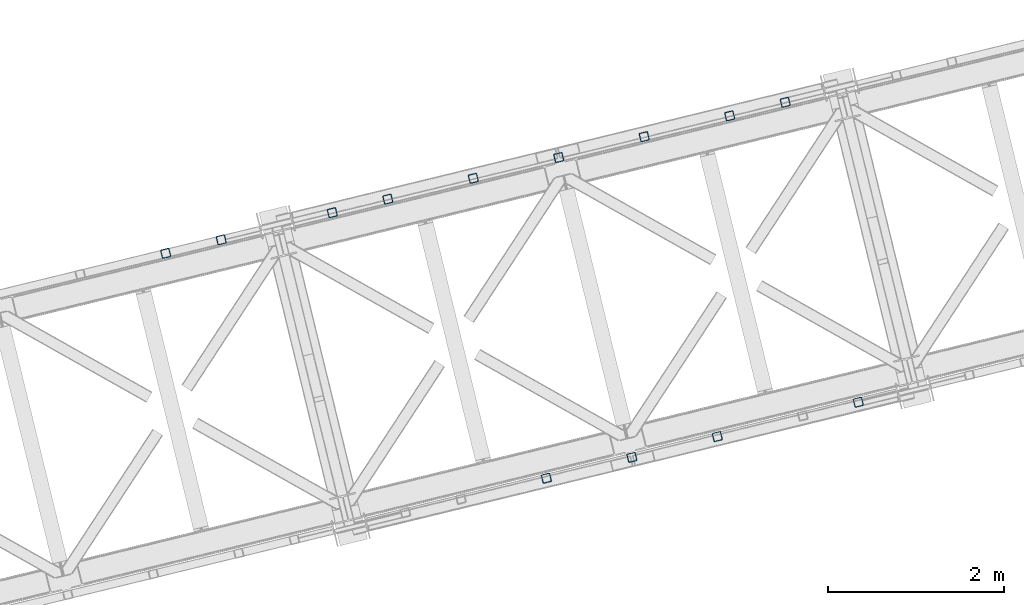
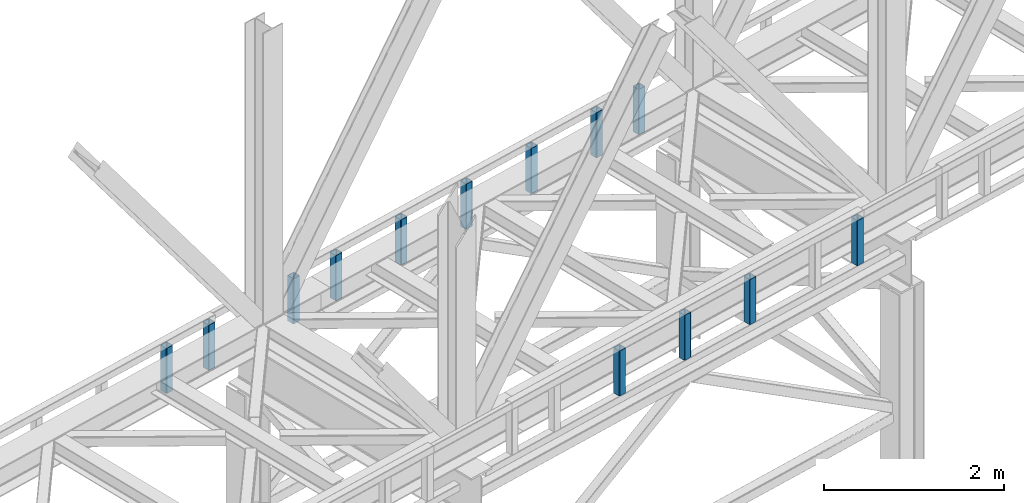
# One storey, part 7 of 92: 13 columns.
"""IFC4 building model written with IfcOpenShell, lengths in millimetres."""

import ifcopenshell
import ifcopenshell.guid

model = None  # the IFC model being written
_history = None  # IfcOwnerHistory: only IFC2X3 demands one
_inside = {}  # id of a spatial element -> (the spatial element, [elements in it])
_under = {}  # id of a project, library or spatial element -> (it, [spatial elements below it])
_declared = {}  # id of a project -> (the project, [libraries it declares])
_typed = {}  # id of a type object -> (the type object, [elements of that type])
_made_of = {}  # id of a material, layer set ... -> (it, [elements and type objects made of it])


def new_model(schema):
    """Start an empty IFC model of exactly this schema.

    Asked for "IFC4X3", IfcOpenShell would pick the latest addendum, in which some entities
    have other attributes; the version numbers below select the first issue.
    IFC2X3 requires an IfcOwnerHistory on every rooted entity: one is made here for all.
    """
    global model, _history
    if schema == "IFC4X3":
        model = ifcopenshell.file(schema_version=(4, 3, 0, 0))
    else:
        model = ifcopenshell.file(schema=schema)
    _inside.clear()
    _under.clear()
    _declared.clear()
    _typed.clear()
    _made_of.clear()
    _history = None
    if model.schema == "IFC2X3":
        org = make("IfcOrganization", Name="unknown")
        user = make(
            "IfcPersonAndOrganization",
            ThePerson=make("IfcPerson", FamilyName="unknown"),
            TheOrganization=org,
        )
        app = make(
            "IfcApplication",
            ApplicationDeveloper=org,
            Version="unknown",
            ApplicationFullName="unknown",
            ApplicationIdentifier="unknown",
        )
        _history = make(
            "IfcOwnerHistory",
            OwningUser=user,
            OwningApplication=app,
            ChangeAction="ADDED",
            CreationDate=0,
        )
    return model


def make(cls, **values):
    """One entity of the class cls with the attributes given. An attribute that is None is left unset."""
    return model.create_entity(
        cls, **{name: value for name, value in values.items() if value is not None}
    )


def entity(cls, *values):
    """Any entity or typed value of the class cls, its attributes in the order of the schema. None: left unset."""
    e = model.create_entity(cls)
    for i, value in enumerate(values):
        if value is not None:
            e[i] = value
    return e


def rooted(cls, **values):
    """An entity with a GlobalId (a new one), such as an element, a storey or a relation."""
    return make(cls, GlobalId=ifcopenshell.guid.new(), OwnerHistory=_history, **values)


def si_unit(unit_type, name, prefix=None):
    """IfcSIUnit, for example si_unit("LENGTHUNIT", "METRE", prefix="MILLI")."""
    return make("IfcSIUnit", UnitType=unit_type, Prefix=prefix, Name=name)


def converted_unit(unit_type, name, factor, base, dimensions=None, offset=None):
    """IfcConversionBasedUnit, such as the inch: factor (a typed value) times the base unit."""
    return make(
        "IfcConversionBasedUnit"
        if offset is None
        else "IfcConversionBasedUnitWithOffset",
        ConversionOffset=offset,
        Dimensions=None
        if dimensions is None
        else entity("IfcDimensionalExponents", *dimensions),
        UnitType=unit_type,
        Name=name,
        ConversionFactor=make(
            "IfcMeasureWithUnit", ValueComponent=factor, UnitComponent=base
        ),
    )


def derived_unit(unit_type, elements):
    """IfcDerivedUnit: a product of units, each with its exponent."""
    return make(
        "IfcDerivedUnit",
        Elements=[
            make("IfcDerivedUnitElement", Unit=unit, Exponent=power)
            for unit, power in elements
        ],
        UnitType=unit_type,
    )


def assignment(units):
    """IfcUnitAssignment: the units of a project."""
    return None if units is None else make("IfcUnitAssignment", Units=units)


def point(xyz):
    """IfcCartesianPoint."""
    return None if xyz is None else make("IfcCartesianPoint", Coordinates=xyz)


def direction(xyz):
    """IfcDirection."""
    return None if xyz is None else make("IfcDirection", DirectionRatios=xyz)


def frame(location, z_axis=None, x_axis=None):
    """IfcAxis2Placement3D, a coordinate frame: its origin and axes. An axis left out is left unset."""
    return make(
        "IfcAxis2Placement3D",
        Location=point(location),
        Axis=direction(z_axis),
        RefDirection=direction(x_axis),
    )


def origin():
    """The frame at (0, 0, 0) with its axes left unset."""
    return frame((0.0, 0.0, 0.0))


def place(relative_to, where):
    """IfcLocalPlacement: puts the frame where relative to a parent placement (None: the world)."""
    return make(
        "IfcLocalPlacement", PlacementRelTo=relative_to, RelativePlacement=where
    )


def context(
    kind, dimensions, precision=None, world=None, true_north=None, identifier=None
):
    """IfcGeometricRepresentationContext, for example the 3D "Model" context."""
    return make(
        "IfcGeometricRepresentationContext",
        ContextIdentifier=identifier,
        ContextType=kind,
        CoordinateSpaceDimension=dimensions,
        Precision=precision,
        WorldCoordinateSystem=world,
        TrueNorth=true_north,
    )


def subcontext(parent, identifier, kind, view, scale=None):
    """IfcGeometricRepresentationSubContext, for example "Body" below "Model"."""
    return make(
        "IfcGeometricRepresentationSubContext",
        ContextIdentifier=identifier,
        ContextType=kind,
        ParentContext=parent,
        TargetScale=scale,
        TargetView=view,
    )


def project(units=None, contexts=None):
    """IfcProject with its units and contexts."""
    return rooted(
        "IfcProject",
        Name="project",
        RepresentationContexts=contexts,
        UnitsInContext=assignment(units),
    )


def spatial(cls, under=None, at=None, **own):
    """A site, building, storey or space (cls), placed at a placement, below another one or the project."""
    s = rooted(cls, ObjectPlacement=at, **own)
    if under is not None:
        _under.setdefault(under.id(), (under, []))[1].append(s)
    return s


def point_list(points):
    """IfcCartesianPointList2D or 3D."""
    cls = (
        "IfcCartesianPointList2D" if len(points[0]) == 2 else "IfcCartesianPointList3D"
    )
    return make(cls, CoordList=points)


def indexed_curve(points, segments=None, self_intersect=None):
    """IfcIndexedPolyCurve: lines and arcs through numbered points (the first is 1)."""
    return make(
        "IfcIndexedPolyCurve",
        Points=point_list(points),
        Segments=segments,
        SelfIntersect=self_intersect,
    )


def outline(outer, holes=None, kind="AREA"):
    """IfcArbitraryClosedProfileDef: a profile drawn as a closed curve; with holes, ...WithVoids."""
    if holes is None:
        return make("IfcArbitraryClosedProfileDef", ProfileType=kind, OuterCurve=outer)
    return make(
        "IfcArbitraryProfileDefWithVoids",
        ProfileType=kind,
        OuterCurve=outer,
        InnerCurves=holes,
    )


def extrude(swept, where, along, depth):
    """IfcExtrudedAreaSolid: the profile swept, set in the frame where, extruded along a direction by depth."""
    return make(
        "IfcExtrudedAreaSolid",
        SweptArea=swept,
        Position=where,
        ExtrudedDirection=direction(along),
        Depth=depth,
    )


def shape(context_of_items, identifier, shape_type, items):
    """IfcShapeRepresentation: the items that make up one representation, for example the "Body"."""
    return make(
        "IfcShapeRepresentation",
        ContextOfItems=context_of_items,
        RepresentationIdentifier=identifier,
        RepresentationType=shape_type,
        Items=items,
    )


def made_of(thing, what):
    """Note that an element or type object is made of a material, layer set ...; save() writes the relation."""
    if what is not None:
        _made_of.setdefault(what.id(), (what, []))[1].append(thing)
    return thing


def type_object(cls, material=None, **own):
    """A type object (cls), such as IfcWallType, which elements share."""
    return made_of(rooted(cls, **own), material)


def element(
    cls,
    number,
    at=None,
    inside=None,
    cuts=None,
    type_object=None,
    material=None,
    context=None,
    identifier="Body",
    shape_type=None,
    held_by="IfcProductDefinitionShape",
    body=None,
    shapes=None,
    **own,
):
    """One element of the class cls, such as IfcWall. Its Tag is "e" and its number.

    at: its placement. inside: the storey or other place that contains it. cuts: it is an
    opening in that element (IfcRelVoidsElement). A single representation is given by context,
    identifier, shape_type and body (its items); several are given by shapes. held_by: the class
    of the entity that holds the representations. save() writes the other relations.
    """
    e = rooted(cls, Tag="e%d" % number, ObjectPlacement=at, **own)
    if body is not None:
        shapes = [shape(context, identifier, shape_type, body)]
    if shapes is not None:
        e.Representation = make(held_by, Representations=shapes)
    if inside is not None:
        _inside.setdefault(inside.id(), (inside, []))[1].append(e)
    if cuts is not None:
        rooted(
            "IfcRelVoidsElement", RelatingBuildingElement=cuts, RelatedOpeningElement=e
        )
    if type_object is not None:
        _typed.setdefault(type_object.id(), (type_object, []))[1].append(e)
    return made_of(e, material)


def aggregate(whole, parts):
    """IfcRelAggregates: a whole, such as a stair, and the parts it consists of."""
    return rooted("IfcRelAggregates", RelatingObject=whole, RelatedObjects=parts)


def save(model, path):
    """Write the relations noted so far, then the file.

    IfcRelAggregates (storeys below a building ...), IfcRelContainedInSpatialStructure (elements
    in a storey), IfcRelDefinesByType, IfcRelAssociatesMaterial and IfcRelDeclares: one each for
    every whole, place, type object, material and project.
    """
    for whole, parts in _under.values():
        aggregate(whole, parts)
    for where, things in _inside.values():
        rooted(
            "IfcRelContainedInSpatialStructure",
            RelatedElements=things,
            RelatingStructure=where,
        )
    for kind, things in _typed.values():
        rooted("IfcRelDefinesByType", RelatedObjects=things, RelatingType=kind)
    for what, things in _made_of.values():
        rooted("IfcRelAssociatesMaterial", RelatedObjects=things, RelatingMaterial=what)
    for by, libraries in _declared.values():
        rooted("IfcRelDeclares", RelatingContext=by, RelatedDefinitions=libraries)
    model.write(path)


model = new_model("IFC4")

# Units and contexts
model_context = context("Model", 3, precision=0.01, world=origin(), true_north=direction((6.12303176911189e-17, 1.0)))
plan_context = context("Plan", 3, precision=0.01, world=origin(), true_north=direction((6.12303176911189e-17, 1.0)))
body_context = subcontext(model_context, "Body", "Model", "MODEL_VIEW")
ifc_project = project(units=[si_unit("LENGTHUNIT", "METRE", prefix="MILLI"), si_unit("AREAUNIT", "SQUARE_METRE"), si_unit("VOLUMEUNIT", "CUBIC_METRE"), converted_unit("PLANEANGLEUNIT", "DEGREE", entity("IfcRatioMeasure", 0.0174532925199433), si_unit("PLANEANGLEUNIT", "RADIAN"), dimensions=[0, 0, 0, 0, 0, 0, 0]), si_unit("MASSUNIT", "GRAM", prefix="KILO"), derived_unit("MASSDENSITYUNIT", [(si_unit("MASSUNIT", "GRAM", prefix="KILO"), 1), (si_unit("LENGTHUNIT", "METRE"), -3)]), derived_unit("MOMENTOFINERTIAUNIT", [(si_unit("LENGTHUNIT", "METRE"), 4)]), si_unit("TIMEUNIT", "SECOND"), si_unit("FREQUENCYUNIT", "HERTZ"), si_unit("THERMODYNAMICTEMPERATUREUNIT", "DEGREE_CELSIUS"), derived_unit("THERMALTRANSMITTANCEUNIT", [(si_unit("MASSUNIT", "GRAM", prefix="KILO"), 1), (si_unit("THERMODYNAMICTEMPERATUREUNIT", "KELVIN"), -1), (si_unit("TIMEUNIT", "SECOND"), -3)]), derived_unit("VOLUMETRICFLOWRATEUNIT", [(si_unit("LENGTHUNIT", "METRE"), 3), (si_unit("TIMEUNIT", "SECOND"), -1)]), derived_unit("MASSFLOWRATEUNIT", [(si_unit("MASSUNIT", "GRAM", prefix="KILO"), 1), (si_unit("TIMEUNIT", "SECOND"), -1)]), derived_unit("ROTATIONALFREQUENCYUNIT", [(si_unit("TIMEUNIT", "SECOND"), -1)]), si_unit("ELECTRICCURRENTUNIT", "AMPERE"), si_unit("ELECTRICVOLTAGEUNIT", "VOLT"), si_unit("POWERUNIT", "WATT"), si_unit("FORCEUNIT", "NEWTON", prefix="KILO"), si_unit("ILLUMINANCEUNIT", "LUX"), si_unit("LUMINOUSFLUXUNIT", "LUMEN"), si_unit("LUMINOUSINTENSITYUNIT", "CANDELA"), derived_unit("USERDEFINED", [(si_unit("MASSUNIT", "GRAM", prefix="KILO"), -1), (si_unit("LENGTHUNIT", "METRE"), -2), (si_unit("TIMEUNIT", "SECOND"), 3), (si_unit("LUMINOUSFLUXUNIT", "LUMEN"), 1)]), derived_unit("LINEARVELOCITYUNIT", [(si_unit("LENGTHUNIT", "METRE"), 1), (si_unit("TIMEUNIT", "SECOND"), -1)]), si_unit("PRESSUREUNIT", "PASCAL"), derived_unit("USERDEFINED", [(si_unit("LENGTHUNIT", "METRE"), -2), (si_unit("MASSUNIT", "GRAM", prefix="KILO"), 1), (si_unit("TIMEUNIT", "SECOND"), -2)]), derived_unit("LINEARFORCEUNIT", [(si_unit("MASSUNIT", "GRAM", prefix="KILO"), 1), (si_unit("LENGTHUNIT", "METRE"), 1), (si_unit("TIMEUNIT", "SECOND"), -2), (si_unit("LENGTHUNIT", "METRE"), -1)]), derived_unit("PLANARFORCEUNIT", [(si_unit("MASSUNIT", "GRAM", prefix="KILO"), 1), (si_unit("LENGTHUNIT", "METRE"), 1), (si_unit("TIMEUNIT", "SECOND"), -2), (si_unit("LENGTHUNIT", "METRE"), -2)])], contexts=[model_context, plan_context])

# Site, building, storey
site_placement = place(None, origin())
site = spatial("IfcSite", under=ifc_project, at=site_placement, CompositionType="ELEMENT")
building_placement = place(site_placement, origin())
building = spatial("IfcBuilding", under=site, at=building_placement, CompositionType="ELEMENT")
storey_placement = place(building_placement, frame((0.0, 0.0, 15900.0)))
storey = spatial("IfcBuildingStorey", under=building, at=storey_placement, Name="05", CompositionType="ELEMENT", Elevation=15900.0)

# Columns
column_type_1 = type_object("IfcColumnType", PredefinedType="COLUMN")
placement = place(storey_placement, origin())
element("IfcColumn", 1, at=placement, inside=storey, type_object=column_type_1, ObjectType="Steel Column", PredefinedType="COLUMN", context=body_context, shape_type="SweptSolid", body=[
    extrude(outline(indexed_curve([(29.4768951153029, -56.8428769008198), (33.3787015556228, -56.8428769008198), (36.9835006656554, -55.3497202198148), (39.7424944584929, -52.5907264269884), (41.2356511394991, -48.9859273169536), (56.84287690082, 29.4768951152981), (56.8428769008277, 33.3787015556192), (55.3497202198129, 36.9835006656563), (52.5907264269925, 39.7424944584862), (48.9859273169586, 41.2356511394944), (-29.4768951152941, 56.8428769008181), (-33.3787015556141, 56.8428769008181), (-36.9835006656505, 55.349720219815), (-39.7424944584793, 52.5907264269869), (-41.2356511394904, 48.9859273169519), (-56.8428769008112, -29.4768951152997), (-56.842876900815, -33.3787015556227), (-55.3497202198089, -36.9835006656581), (-52.5907264269837, -39.7424944584879), (-48.9859273169498, -41.2356511394961), (29.4768951153029, -56.8428769008198)], self_intersect=False), holes=[indexed_curve([(-43.1065493048517, -37.307176347563), (-46.7113484148808, -35.8140196665547), (-49.4703422077117, -33.0550258737269), (-50.963498888713, -29.4502267636914), (-50.963498888714, -25.5484203233686), (-37.3071763475533, 43.106549304852), (-35.8140196665462, 46.7113484148888), (-33.0550258737174, 49.4703422077169), (-29.4502267636801, 50.963498888722), (-25.548420323361, 50.96349888872), (43.1065493048614, 37.3071763475633), (46.7113484148896, 35.814019666553), (49.4703422077244, 33.0550258737234), (50.9634988887296, 29.4502267636861), (50.9634988887306, 25.5484203233633), (37.3071763475739, -43.1065493048592), (35.8140196665589, -46.7113484148923), (33.0550258737234, -49.4703422077244), (29.4502267636897, -50.9634988887217), (25.5484203233707, -50.9634988887198), (-43.1065493048517, -37.307176347563)], self_intersect=False)]), frame((-37205.57, 11928.95, 3168.0), z_axis=(0.0, 0.0, 1.0), x_axis=(0.906681479027134, 0.421815949898968, 0.0)), (0.0, 0.0, 1.0), 612.000000000008),
])
column_type_2 = type_object("IfcColumnType", PredefinedType="COLUMN")
element("IfcColumn", 2, at=placement, inside=storey, type_object=column_type_2, ObjectType="Steel Column", PredefinedType="COLUMN", context=body_context, shape_type="SweptSolid", body=[
    extrude(outline(indexed_curve([(29.4768951152981, -56.84287690082), (33.378701555618, -56.84287690082), (36.9835006656544, -55.3497202198168), (39.7424944584841, -52.5907264269867), (41.2356511394982, -48.9859273169556), (56.84287690082, 29.4768951152981), (56.8428769008189, 33.3787015556209), (55.3497202198129, 36.9835006656563), (52.5907264269877, 39.7424944584861), (48.9859273169538, 41.2356511394943), (-29.476895115299, 56.842876900818), (-33.3787015556189, 56.842876900818), (-36.9835006656602, 55.3497202198147), (-39.7424944584841, 52.5907264269867), (-41.2356511394952, 48.9859273169518), (-56.8428769008161, -29.4768951152999), (-56.8428769008198, -33.3787015556229), (-55.3497202198186, -36.9835006656584), (-52.5907264269886, -39.742494458488), (-48.9859273169547, -41.2356511394962), (29.4768951152981, -56.84287690082)], self_intersect=False), holes=[indexed_curve([(-43.1065493048575, -37.3071763475651), (-46.7113484148856, -35.8140196665548), (-49.4703422077187, -33.0550258737213), (-50.9634988887217, -29.4502267636897), (-50.9634988887228, -25.5484203233669), (-37.3071763475621, 43.1065493048537), (-35.8140196665549, 46.7113484148905), (-33.0550258737289, 49.4703422077126), (-29.4502267636858, 50.9634988887199), (-25.5484203233668, 50.9634988887179), (43.1065493048557, 37.3071763475612), (46.7113484148847, 35.8140196665528), (49.4703422077138, 33.0550258737212), (50.9634988887199, 29.4502267636858), (50.9634988887219, 25.548420323365), (37.3071763475612, -43.1065493048557), (35.8140196665501, -46.7113484148906), (33.0550258737223, -49.4703422077167), (29.450226763684, -50.9634988887238), (25.548420323365, -50.9634988887219), (-43.1065493048575, -37.3071763475651)], self_intersect=False)]), frame((-37837.08, 11775.02, 3168.0), z_axis=(0.0, 0.0, 1.0), x_axis=(0.906681479027134, 0.421815949898968, 0.0)), (0.0, 0.0, 1.0), 612.000000000008),
])
column_type_3 = type_object("IfcColumnType", PredefinedType="COLUMN")
element("IfcColumn", 3, at=placement, inside=storey, type_object=column_type_3, ObjectType="Steel Column", PredefinedType="COLUMN", context=body_context, shape_type="SweptSolid", body=[
    extrude(outline(indexed_curve([(29.4768951153059, -56.8428769008236), (33.3787015556259, -56.8428769008236), (36.9835006656662, -55.3497202198223), (39.7424944584998, -52.5907264269941), (41.235651139507, -48.9859273169573), (56.8428769008318, 29.4768951152926), (56.8428769008355, 33.3787015556155), (55.3497202198246, 36.9835006656508), (52.5907264269916, 39.7424944584842), (48.9859273169616, 41.2356511394906), (-29.4768951152911, 56.8428769008144), (-33.3787015556111, 56.8428769008144), (-36.9835006656436, 55.3497202198093), (-39.7424944584723, 52.5907264269813), (-41.2356511394873, 48.9859273169481), (-56.8428769008082, -29.4768951153035), (-56.8428769008071, -33.3787015556264), (-55.349720219802, -36.9835006656637), (-52.5907264269807, -39.7424944584917), (-48.9859273169468, -41.2356511394999), (29.4768951153059, -56.8428769008236)], self_intersect=False), holes=[indexed_curve([(-43.1065493048478, -37.3071763475648), (-46.7113484148729, -35.8140196665583), (-49.4703422077021, -33.0550258737267), (-50.9634988887051, -29.4502267636951), (-50.9634988887053, -25.5484203233703), (-37.3071763475464, 43.1065493048464), (-35.8140196665383, 46.7113484148851), (-33.0550258737096, 49.4703422077132), (-29.450226763677, 50.9634988887182), (-25.5484203233571, 50.9634988887182), (43.1065493048644, 37.3071763475595), (46.7113484149032, 35.8140196665514), (49.4703422077305, 33.0550258737158), (50.9634988887326, 29.4502267636823), (50.9634988887385, 25.5484203233596), (37.3071763475778, -43.106549304861), (35.8140196665685, -46.711348414892), (33.0550258737389, -49.4703422077221), (29.4502267636928, -50.9634988887255), (25.5484203233737, -50.9634988887236), (-43.1065493048478, -37.3071763475648)], self_intersect=False)]), frame((-38808.63, 11538.19, 3168.0), z_axis=(0.0, 0.0, 1.0), x_axis=(0.906681479027134, 0.421815949898968, 0.0)), (0.0, 0.0, 1.0), 612.000000000008),
])
column_type_4 = type_object("IfcColumnType", PredefinedType="COLUMN")
element("IfcColumn", 4, at=placement, inside=storey, type_object=column_type_4, ObjectType="Steel Column", PredefinedType="COLUMN", context=body_context, shape_type="SweptSolid", body=[
    extrude(outline(indexed_curve([(29.4768951152932, -56.8428769008201), (33.3787015556132, -56.8428769008201), (36.9835006656584, -55.3497202198186), (39.7424944584832, -52.5907264269887), (41.2356511394894, -48.9859273169539), (56.8428769008112, 29.4768951152998), (56.8428769008189, 33.3787015556209), (55.3497202198129, 36.9835006656563), (52.5907264269789, 39.7424944584878), (48.985927316945, 41.235651139496), (-29.4768951153029, 56.8428769008198), (-33.3787015556228, 56.8428769008198), (-36.9835006656602, 55.3497202198147), (-39.7424944584929, 52.5907264269884), (-41.2356511394991, 48.9859273169536), (-56.8428769008209, -29.4768951153001), (-56.8428769008198, -33.3787015556229), (-55.3497202198225, -36.9835006656566), (-52.5907264269886, -39.7424944584881), (-48.9859273169547, -41.2356511394963), (29.4768951152932, -56.8428769008201)], self_intersect=False), holes=[indexed_curve([(-43.1065493048575, -37.3071763475651), (-46.7113484148905, -35.814019666555), (-49.4703422077244, -33.0550258737235), (-50.9634988887217, -29.4502267636898), (-50.9634988887228, -25.5484203233669), (-37.3071763475621, 43.1065493048537), (-35.8140196665628, 46.7113484148941), (-33.0550258737223, 49.4703422077167), (-29.4502267636937, 50.9634988887235), (-25.5484203233746, 50.9634988887216), (43.1065493048557, 37.3071763475612), (46.7113484148808, 35.8140196665547), (49.4703422077157, 33.0550258737252), (50.9634988887199, 29.4502267636858), (50.963498888714, 25.5484203233686), (37.3071763475612, -43.1065493048556), (35.8140196665471, -46.7113484148868), (33.0550258737117, -49.4703422077189), (29.450226763684, -50.9634988887238), (25.548420323365, -50.9634988887219), (-43.1065493048575, -37.3071763475651)], self_intersect=False)]), frame((-39780.18, 11301.36, 3168.0), z_axis=(0.0, 0.0, 1.0), x_axis=(0.906681479027134, 0.421815949898968, 0.0)), (0.0, 0.0, 1.0), 612.000000000008),
])
column_type_5 = type_object("IfcColumnType", PredefinedType="COLUMN")
element("IfcColumn", 5, at=placement, inside=storey, type_object=column_type_5, ObjectType="Steel Column", PredefinedType="COLUMN", context=body_context, shape_type="SweptSolid", body=[
    extrude(outline(indexed_curve([(29.4768951153483, -56.8428769007886), (33.3787015556761, -56.8428769007886), (36.9835006657111, -55.349720219782), (39.7424944585412, -52.5907264269532), (41.235651139545, -48.985927316915), (56.8428769007924, 29.4768951153513), (56.8428769007886, 33.3787015556761), (55.3497202197791, 36.9835006657101), (52.5907264269514, 39.7424944585373), (48.985927316916, 41.2356511395421), (-29.4768951153474, 56.8428769007905), (-33.3787015556752, 56.8428769007905), (-36.9835006657111, 55.349720219782), (-39.7424944585412, 52.5907264269532), (-41.2356511395362, 48.9859273169133), (-56.8428769007924, -29.4768951153513), (-56.8428769007886, -33.3787015556761), (-55.3497202197782, -36.9835006657081), (-52.5907264269504, -39.7424944585353), (-48.9859273169151, -41.2356511395401), (29.4768951153483, -56.8428769007886)], self_intersect=False), holes=[indexed_curve([(-43.1065493048216, -37.3071763476035), (-46.7113484148569, -35.8140196665987), (-49.4703422076838, -33.0550258737695), (-50.9634988886854, -29.4502267637392), (-50.9634988886901, -25.5484203234163), (-37.3071763475946, 43.1065493048151), (-35.8140196665917, 46.7113484148513), (-33.0550258737598, 49.4703422076841), (-29.4502267637405, 50.9634988886979), (-25.5484203234214, 50.9634988886996), (43.1065493048216, 37.3071763476035), (46.711348414863, 35.8140196665911), (49.4703422076926, 33.0550258737678), (50.963498888702, 29.4502267637338), (50.9634988887067, 25.548420323411), (37.3071763476103, -43.1065493048224), (35.8140196665996, -46.711348414855), (33.0550258737686, -49.4703422076858), (29.4502267637405, -50.9634988886979), (25.5484203234136, -50.963498888696), (-43.1065493048216, -37.3071763476035)], self_intersect=False)]), frame((-40751.73, 11064.54, 3168.0), z_axis=(0.0, 0.0, 1.0), x_axis=(0.906681479027529, 0.421815949898119, 0.0)), (0.0, 0.0, 1.0), 612.000000000008),
])
column_type_6 = type_object("IfcColumnType", PredefinedType="COLUMN")
element("IfcColumn", 6, at=placement, inside=storey, type_object=column_type_6, ObjectType="Steel Column", PredefinedType="COLUMN", context=body_context, shape_type="SweptSolid", body=[
    extrude(outline(indexed_curve([(29.476895115376, -56.8428769007757), (33.3787015557029, -56.8428769007757), (36.9835006657302, -55.3497202197617), (39.7424944585589, -52.5907264269315), (41.23565113956, -48.9859273168945), (56.8428769007766, 29.4768951153779), (56.8428769007709, 33.3787015557027), (55.3497202197596, 36.983500665736), (52.5907264269295, 39.7424944585598), (48.9859273168944, 41.2356511395648), (-29.4768951153857, 56.8428769007754), (-33.3787015557135, 56.8428769007735), (-36.9835006657399, 55.3497202197614), (-39.7424944585686, 52.5907264269312), (-41.2356511395706, 48.9859273168923), (-56.8428769007872, -29.4768951153802), (-56.8428769007727, -33.3787015557067), (-55.3497202197693, -36.9835006657362), (-52.5907264269401, -39.7424944585621), (-48.9859273169041, -41.2356511395651), (29.476895115376, -56.8428769007757)], self_intersect=False), holes=[indexed_curve([(-43.106549304795, -37.3071763476288), (-46.711348414838, -35.8140196666202), (-49.4703422076759, -33.0550258737927), (-50.9634988886802, -29.4502267637651), (-50.963498888686, -25.5484203234403), (-37.3071763476251, 43.106549304798), (-35.8140196666231, 46.7113484148369), (-33.0550258737953, 49.4703422076652), (-29.4502267637661, 50.9634988886831), (-25.5484203234392, 50.9634988886831), (43.1065493047941, 37.3071763476269), (46.711348414838, 35.8140196666202), (49.4703422076672, 33.0550258737944), (50.9634988886784, 29.4502267637612), (50.9634988886851, 25.5484203234383), (37.3071763476232, -43.1065493048019), (35.8140196666213, -46.7113484148409), (33.0550258737944, -49.4703422076672), (29.4502267637661, -50.9634988886831), (25.5484203234383, -50.9634988886851), (-43.106549304795, -37.3071763476288)], self_intersect=False)]), frame((-41723.28, 10827.71, 3168.0), z_axis=(0.0, 0.0, 1.0), x_axis=(0.906681479027741, 0.421815949897663, 0.0)), (0.0, 0.0, 1.0), 612.000000000008),
])
column_type_7 = type_object("IfcColumnType", PredefinedType="COLUMN")
element("IfcColumn", 7, at=placement, inside=storey, type_object=column_type_7, ObjectType="Steel Column", PredefinedType="COLUMN", context=body_context, shape_type="SweptSolid", body=[
    extrude(outline(indexed_curve([(29.4768951153089, -56.8428769008274), (33.3787015556289, -56.8428769008274), (36.9835006656662, -55.3497202198223), (39.7424944584989, -52.590726426996), (41.2356511395051, -48.9859273169612), (56.8428769008269, 29.4768951152924), (56.8428769008337, 33.3787015556116), (55.3497202198277, 36.983500665647), (52.5907264269946, 39.7424944584805), (48.9859273169607, 41.2356511394887), (-29.4768951152881, 56.8428769008106), (-33.3787015556159, 56.8428769008142), (-36.9835006656445, 55.3497202198074), (-39.7424944584772, 52.5907264269811), (-41.2356511394843, 48.9859273169444), (-56.842876900814, -29.4768951153056), (-56.8428769008129, -33.3787015556285), (-55.3497202198068, -36.9835006656639), (-52.5907264269816, -39.7424944584937), (-48.9859273169477, -41.2356511395018), (29.4768951153089, -56.8428769008274)], self_intersect=False), holes=[indexed_curve([(-43.1065493048496, -37.3071763475687), (-46.7113484148826, -35.8140196665586), (-49.4703422077175, -33.0550258737291), (-50.9634988887148, -29.4502267636954), (-50.9634988887071, -25.5484203233742), (-37.3071763475551, 43.1065493048481), (-35.8140196665411, 46.7113484148792), (-33.0550258737144, 49.4703422077131), (-29.4502267636867, 50.9634988887179), (-25.5484203233668, 50.9634988887179), (43.1065493048547, 37.3071763475592), (46.7113484148974, 35.8140196665493), (49.4703422077305, 33.0550258737158), (50.9634988887287, 29.4502267636841), (50.9634988887288, 25.5484203233593), (37.3071763475681, -43.1065493048613), (35.814019666561, -46.7113484148981), (33.0550258737223, -49.4703422077167), (29.4502267636918, -50.9634988887275), (25.5484203233719, -50.9634988887275), (-43.1065493048496, -37.3071763475687)], self_intersect=False)]), frame((-42354.79, 10673.78, 3168.0), z_axis=(0.0, 0.0, 1.0), x_axis=(0.906681479027134, 0.421815949898968, 0.0)), (0.0, 0.0, 1.0), 612.000000000008),
])
column_type_8 = type_object("IfcColumnType", PredefinedType="COLUMN")
element("IfcColumn", 8, at=placement, inside=storey, type_object=column_type_8, ObjectType="Steel Column", PredefinedType="COLUMN", context=body_context, shape_type="SweptSolid", body=[
    extrude(outline(indexed_curve([(29.4768951153552, -56.8428769007942), (33.378701555683, -56.8428769007942), (36.983500665719, -55.3497202197857), (39.7424944585412, -52.5907264269532), (41.2356511395441, -48.985927316917), (56.8428769008002, 29.4768951153476), (56.8428769007964, 33.3787015556724), (55.349720219787, 36.9835006657064), (52.5907264269583, 39.7424944585317), (48.9859273169151, 41.2356511395401), (-29.4768951153474, 56.8428769007906), (-33.3787015556673, 56.8428769007869), (-36.9835006657033, 55.3497202197784), (-39.7424944585334, 52.5907264269495), (-41.2356511395371, 48.9859273169114), (-56.8428769007845, -29.4768951153549), (-56.8428769007807, -33.3787015556797), (-55.3497202197713, -36.9835006657137), (-52.5907264269426, -39.742494458539), (-48.9859273169082, -41.2356511395457), (29.4768951153552, -56.8428769007942)], self_intersect=False), holes=[indexed_curve([(-43.1065493048138, -37.3071763476071), (-46.711348414856, -35.8140196665967), (-49.4703422076856, -33.0550258737734), (-50.9634988886863, -29.4502267637411), (-50.9634988886832, -25.5484203234219), (-37.3071763475946, 43.1065493048151), (-35.8140196665917, 46.7113484148513), (-33.0550258737607, 49.4703422076821), (-29.4502267637335, 50.9634988886923), (-25.5484203234136, 50.963498888696), (43.1065493048129, 37.3071763476052), (46.7113484148648, 35.814019666595), (49.4703422076917, 33.0550258737658), (50.9634988887011, 29.4502267637318), (50.9634988887058, 25.548420323409), (37.3071763476094, -43.1065493048244), (35.8140196665978, -46.7113484148589), (33.0550258737686, -49.4703422076858), (29.4502267637317, -50.9634988886963), (25.5484203234205, -50.9634988887016), (-43.1065493048138, -37.3071763476071)], self_intersect=False)]), frame((-43617.81, 10365.9, 3168.0), z_axis=(0.0, 0.0, 1.0), x_axis=(0.906681479027529, 0.421815949898119, 0.0)), (0.0, 0.0, 1.0), 612.000000000008),
])
column_type_9 = type_object("IfcColumnType", PredefinedType="COLUMN")
element("IfcColumn", 9, at=placement, inside=storey, type_object=column_type_9, ObjectType="Steel Column", PredefinedType="COLUMN", context=body_context, shape_type="SweptSolid", body=[
    extrude(outline(indexed_curve([(29.4768951153257, -56.842876900811), (33.3787015556544, -56.842876900811), (36.9835006656902, -55.3497202198063), (39.7424944585138, -52.5907264269752), (41.2356511395273, -48.9859273169414), (56.8428769008141, 29.476895115317), (56.8428769008123, 33.3787015556418), (55.3497202198047, 36.9835006656766), (52.5907264269783, 39.7424944585052), (48.9859273169437, 41.2356511395118), (-29.4768951153197, 56.8428769008034), (-33.3787015556396, 56.8428769008018), (-36.9835006656763, 55.349720219795), (-39.7424944585078, 52.5907264269676), (-41.2356511395125, 48.9859273169321), (-56.8428769008003, -29.4768951153283), (-56.8428769007984, -33.3787015556531), (-55.3497202197899, -36.9835006656858), (-52.5907264269635, -39.7424944585144), (-48.9859273169289, -41.2356511395211), (29.4768951153257, -56.842876900811)], self_intersect=False), holes=[indexed_curve([(-43.1065493048256, -37.307176347591), (-46.711348414875, -35.8140196665751), (-49.4703422077023, -33.0550258737485), (-50.9634988886942, -29.4502267637211), (-50.963498888696, -25.5484203233963), (-37.307176347565, 43.1065493048302), (-35.8140196665682, 46.7113484148694), (-33.0550258737367, 49.4703422076968), (-29.4502267637088, 50.9634988887052), (-25.5484203233879, 50.9634988887089), (43.1065493048395, 37.3071763475798), (46.7113484148819, 35.8140196665695), (49.4703422077074, 33.0550258737389), (50.9634988887238, 29.4502267637025), (50.9634988887177, 25.5484203233814), (37.3071763475955, -43.1065493048468), (35.8140196665743, -46.711348414877), (33.0550258737428, -49.4703422077044), (29.4502267637139, -50.9634988887148), (25.5484203234018, -50.9634988887201), (-43.1065493048256, -37.307176347591)], self_intersect=False)]), frame((-44249.32, 10211.96, 3168.0), z_axis=(0.0, 0.0, 1.0), x_axis=(0.906681479027317, 0.421815949898576, 0.0)), (0.0, 0.0, 1.0), 612.000000000008),
])
column_type_10 = type_object("IfcColumnType", PredefinedType="COLUMN")
element("IfcColumn", 10, at=placement, inside=storey, type_object=column_type_10, ObjectType="Steel Column", PredefinedType="COLUMN", context=body_context, shape_type="SweptSolid", body=[
    extrude(outline(indexed_curve([(29.4768951153054, -56.8428769008069), (33.3787015556249, -56.8428769008069), (36.9835006656614, -55.3497202198019), (39.7424944584899, -52.5907264269721), (41.2356511394992, -48.9859273169387), (56.8428769008008, 29.4768951153178), (56.8428769008031, 33.3787015556398), (55.3497202197966, 36.9835006656758), (52.5907264269663, 39.7424944585058), (48.9859273169364, 41.2356511395122), (-29.4768951153202, 56.8428769008162), (-33.3787015556436, 56.842876900818), (-36.9835006656723, 55.3497202198093), (-39.7424944585091, 52.5907264269822), (-41.235651139514, 48.985927316948), (-56.842876900816, -29.4768951153096), (-56.8428769008228, -33.3787015556307), (-55.349720219807, -36.9835006656674), (-52.5907264269855, -39.7424944584957), (-48.9859273169512, -41.2356511395029), (29.4768951153054, -56.8428769008069)], self_intersect=False), holes=[indexed_curve([(-43.1065493048546, -37.3071763475693), (-46.7113484148879, -35.8140196665601), (-49.4703422077196, -33.0550258737331), (-50.9634988887261, -29.4502267636971), (-50.9634988887268, -25.5484203233713), (-37.3071763475882, 43.1065493048526), (-35.8140196665741, 46.7113484148861), (-33.0550258737398, 49.4703422077179), (-29.45022676371, 50.963498888719), (-25.5484203233861, 50.9634988887181), (43.1065493048349, 37.3071763475785), (46.7113484148692, 35.8140196665712), (49.4703422077004, 33.0550258737432), (50.9634988887025, 29.450226763708), (50.9634988887041, 25.5484203233842), (37.3071763475611, -43.1065493048388), (35.8140196665554, -46.711348414875), (33.0550258737225, -49.4703422077039), (29.4502267636903, -50.9634988887098), (25.5484203233704, -50.9634988887108), (-43.1065493048546, -37.3071763475693)], self_intersect=False)]), frame((-36374.54, 8519.78, 3168.0), z_axis=(0.0, 0.0, 1.0), x_axis=(-0.90668147902724, -0.42181594989874, 0.0)), (0.0, 0.0, 1.0), 612.000000000008),
])
column_type_11 = type_object("IfcColumnType", PredefinedType="COLUMN")
element("IfcColumn", 11, at=placement, inside=storey, type_object=column_type_11, ObjectType="Steel Column", PredefinedType="COLUMN", context=body_context, shape_type="SweptSolid", body=[
    extrude(outline(indexed_curve([(29.4768951153098, -56.8428769008078), (33.3787015556293, -56.8428769008078), (36.9835006656619, -55.3497202198009), (39.7424944584899, -52.5907264269721), (41.2356511395036, -48.9859273169396), (56.8428769008056, 29.476895115318), (56.8428769008036, 33.3787015556408), (55.3497202197966, 36.9835006656758), (52.5907264269751, 39.7424944585041), (48.9859273169408, 41.2356511395114), (-29.4768951153158, 56.8428769008154), (-33.3787015556353, 56.8428769008154), (-36.9835006656762, 55.3497202198111), (-39.7424944585091, 52.5907264269822), (-41.2356511395184, 48.9859273169489), (-56.84287690082, -29.4768951153077), (-56.8428769008223, -33.3787015556297), (-55.3497202198114, -36.9835006656666), (-52.5907264269767, -39.7424944584974), (-48.9859273169464, -41.2356511395028), (29.4768951153098, -56.8428769008078)], self_intersect=False), holes=[indexed_curve([(-43.1065493048497, -37.3071763475692), (-46.7113484148898, -35.814019666564), (-49.4703422077173, -33.0550258737282), (-50.9634988887199, -29.450226763694), (-50.9634988887263, -25.5484203233703), (-37.3071763475838, 43.1065493048517), (-35.814019666575, 46.7113484148841), (-33.0550258737456, 49.4703422077158), (-29.4502267637047, 50.9634988887201), (-25.5484203233812, 50.9634988887182), (43.1065493048393, 37.3071763475776), (46.7113484148727, 35.8140196665684), (49.4703422076986, 33.0550258737393), (50.963498888703, 29.450226763709), (50.9634988887037, 25.5484203233833), (37.307176347562, -43.1065493048369), (35.8140196665558, -46.711348414874), (33.0550258737229, -49.4703422077029), (29.4502267636952, -50.9634988887097), (25.5484203233752, -50.9634988887107), (-43.1065493048497, -37.3071763475692)], self_intersect=False)]), frame((-37977.61, 8129.01, 3168.0), z_axis=(0.0, 0.0, 1.0), x_axis=(-0.90668147902724, -0.42181594989874, 0.0)), (0.0, 0.0, 1.0), 612.000000000008),
])
column_type_12 = type_object("IfcColumnType", PredefinedType="COLUMN")
element("IfcColumn", 12, at=placement, inside=storey, type_object=column_type_12, ObjectType="Steel Column", PredefinedType="COLUMN", context=body_context, shape_type="SweptSolid", body=[
    extrude(outline(indexed_curve([(29.4768951153089, -56.8428769008097), (33.3787015556284, -56.8428769008097), (36.9835006656654, -55.3497202198037), (39.7424944584934, -52.5907264269749), (41.2356511395027, -48.9859273169415), (56.8428769008047, 29.476895115316), (56.842876900807, 33.378701555638), (55.3497202198001, 36.983500665673), (52.5907264269742, 39.7424944585021), (48.9859273169399, 41.2356511395094), (-29.4768951153167, 56.8428769008134), (-33.3787015556362, 56.8428769008134), (-36.9835006656771, 55.3497202198092), (-39.7424944585056, 52.5907264269794), (-41.2356511395105, 48.9859273169452), (-56.8428769008121, -29.4768951153114), (-56.8428769008188, -33.3787015556325), (-55.3497202198123, -36.9835006656685), (-52.5907264269816, -39.7424944584975), (-48.9859273169473, -41.2356511395048), (29.4768951153089, -56.8428769008097)], self_intersect=False), holes=[indexed_curve([(-43.1065493048506, -37.3071763475712), (-46.7113484148849, -35.8140196665639), (-49.4703422077078, -33.0550258737386), (-50.9634988887178, -29.4502267636998), (-50.9634988887198, -25.5484203233769), (-37.3071763475764, 43.1065493048471), (-35.814019666572, 46.7113484148803), (-33.0550258737368, 49.4703422077141), (-29.450226763706, 50.9634988887171), (-25.5484203233822, 50.9634988887163), (43.1065493048389, 37.3071763475766), (46.7113484148722, 35.8140196665674), (49.4703422077073, 33.0550258737376), (50.9634988887095, 29.4502267637024), (50.9634988887111, 25.5484203233786), (37.3071763475681, -43.1065493048444), (35.8140196665623, -46.7113484148806), (33.0550258737255, -49.4703422077077), (29.4502267636943, -50.9634988887116), (25.5484203233743, -50.9634988887126), (-43.1065493048506, -37.3071763475712)], self_intersect=False)]), frame((-38949.16, 7892.19, 3168.0), z_axis=(0.0, 0.0, 1.0), x_axis=(-0.90668147902724, -0.42181594989874, 0.0)), (0.0, 0.0, 1.0), 612.000000000008),
])
column_type_13 = type_object("IfcColumnType", PredefinedType="COLUMN")
element("IfcColumn", 13, at=placement, inside=storey, type_object=column_type_13, ObjectType="Steel Column", PredefinedType="COLUMN", context=body_context, shape_type="SweptSolid", body=[
    extrude(outline(indexed_curve([(29.4768951153098, -56.8428769008255), (33.3787015556298, -56.8428769008255), (36.9835006656671, -55.3497202198203), (39.7424944585003, -52.5907264269931), (41.2356511395061, -48.9859273169592), (56.8428769008278, 29.4768951152944), (56.8428769008351, 33.3787015556146), (55.349720219829, 36.9835006656499), (52.5907264269955, 39.7424944584824), (48.9859273169621, 41.2356511394916), (-29.4768951152867, 56.8428769008135), (-33.3787015556145, 56.8428769008172), (-36.9835006656436, 55.3497202198093), (-39.7424944584767, 52.5907264269821), (-41.2356511394829, 48.9859273169473), (-56.8428769008121, -29.4768951153017), (-56.8428769008115, -33.3787015556255), (-55.3497202198055, -36.9835006656609), (-52.5907264269803, -39.7424944584907), (-48.9859273169385, -41.2356511395026), (29.4768951153098, -56.8428769008255)], self_intersect=False), holes=[indexed_curve([(-43.1065493048404, -37.3071763475695), (-46.7113484148813, -35.8140196665556), (-49.4703422077083, -33.0550258737298), (-50.9634988887139, -29.4502267636934), (-50.9634988887149, -25.5484203233706), (-37.3071763475542, 43.10654930485), (-35.8140196665484, 46.7113484148839), (-33.0550258737144, 49.4703422077131), (-29.450226763678, 50.9634988887163), (-25.5484203233502, 50.9634988887126), (43.1065493048714, 37.3071763475538), (46.7113484148979, 35.8140196665503), (49.4703422077221, 33.0550258737185), (50.9634988887291, 29.4502267636851), (50.9634988887288, 25.5484203233593), (37.3071763475695, -43.1065493048583), (35.8140196665637, -46.7113484148922), (33.0550258737296, -49.4703422077214), (29.4502267637006, -50.9634988887292), (25.5484203233811, -50.9634988887282), (-43.1065493048404, -37.3071763475695)], self_intersect=False)]), frame((-39920.71, 7655.36, 3168.0), z_axis=(0.0, 0.0, 1.0), x_axis=(-0.906681479027134, -0.421815949898968, 0.0)), (0.0, 0.0, 1.0), 612.000000000008),
])

save(model, "model.ifc")
